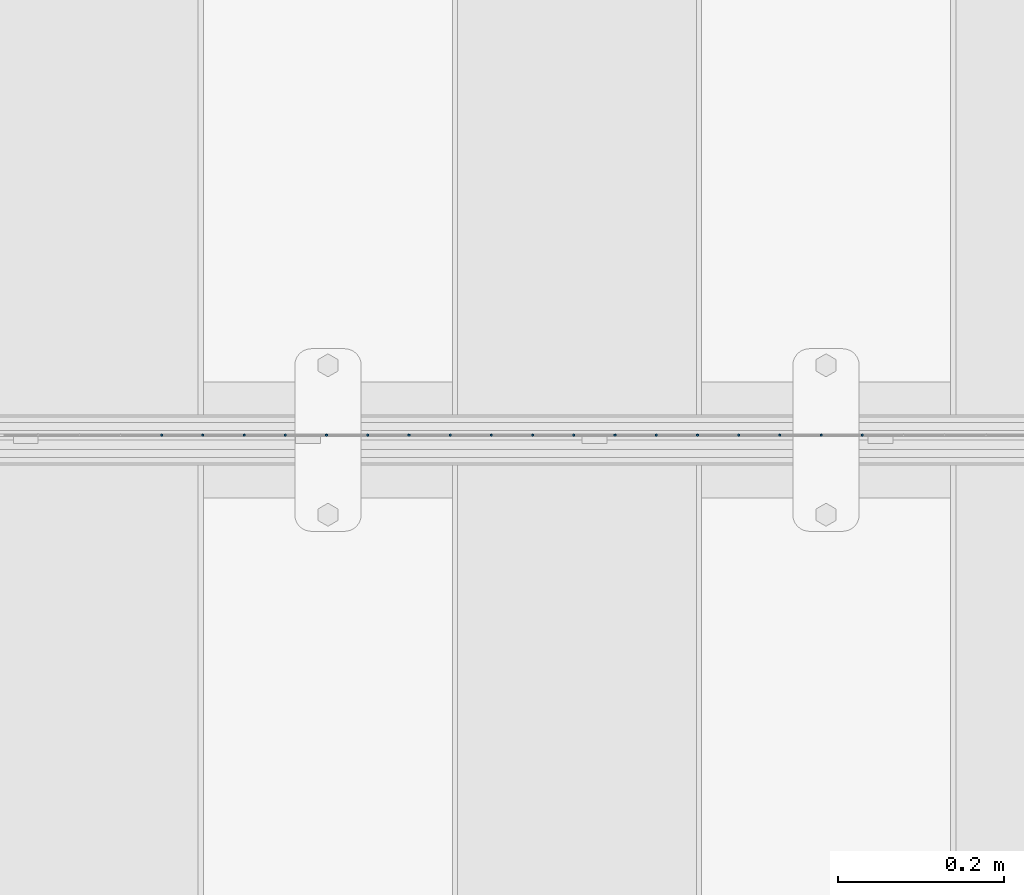
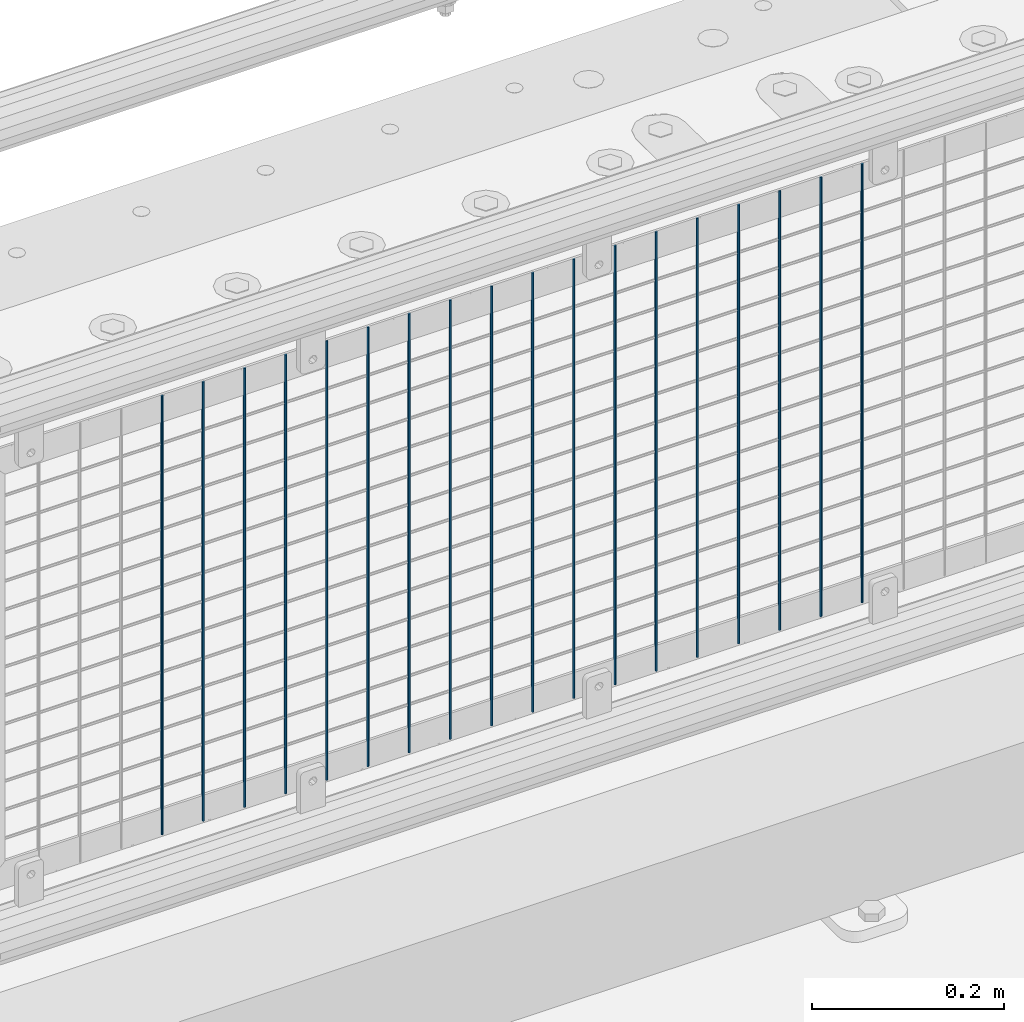
# One storey, part 61 of 208: 18 columns.
"""IFC2X3 building model written with IfcOpenShell, lengths in millimetres."""

from ifc_helpers import new_model, si_unit, frame, origin_with_axes, place, context, subcontext, project, spatial, faceted_brep, material, type_object, element, save


model = new_model("IFC2X3")

# Units and contexts
model_context = context("Model", 3, precision=1e-05, world=origin_with_axes())
body_context = subcontext(model_context, "Body", "Model", "MODEL_VIEW")
ifc_project = project(units=[si_unit("LENGTHUNIT", "METRE", prefix="MILLI"), si_unit("AREAUNIT", "SQUARE_METRE"), si_unit("VOLUMEUNIT", "CUBIC_METRE"), si_unit("MASSUNIT", "GRAM", prefix="KILO"), si_unit("TIMEUNIT", "SECOND"), si_unit("PLANEANGLEUNIT", "RADIAN"), si_unit("SOLIDANGLEUNIT", "STERADIAN"), si_unit("THERMODYNAMICTEMPERATUREUNIT", "DEGREE_CELSIUS"), si_unit("LUMINOUSINTENSITYUNIT", "LUMEN")], contexts=[model_context])

# Site, building, storey
site_placement = place(None, origin_with_axes())
site = spatial("IfcSite", under=ifc_project, at=site_placement, CompositionType="ELEMENT")
building_placement = place(site_placement, origin_with_axes())
building = spatial("IfcBuilding", under=site, at=building_placement, Name="Standard", CompositionType="ELEMENT")
storey_placement = place(building_placement, origin_with_axes())
storey = spatial("IfcBuildingStorey", under=building, at=storey_placement, Name="Undefined", CompositionType="ELEMENT", Elevation=0.0)

# Columns
ifc_material = material(Name="Misc_Undefined")
column_type = type_object("IfcColumnType", Name="D3", PredefinedType="NOTDEFINED")
for number, where, z_axis, x_axis in (
    (1, (-37506.245, 4670.5, 353.02), (-1.0, 0.0, 0.0), (0.0, 0.0, 1.0)),
    (2, (-37555.9, 4670.5, 353.02), (-1.0, 0.0, 0.0), (0.0, 0.0, 1.0)),
    (3, (-37605.555, 4670.5, 353.02), (-1.0, 0.0, 0.0), (0.0, 0.0, 1.0)),
    (4, (-37655.21, 4670.5, 353.02), (-1.0, 0.0, 0.0), (0.0, 0.0, 1.0)),
    (5, (-37704.865, 4670.5, 353.02), (-1.0, 0.0, 0.0), (0.0, 0.0, 1.0)),
    (6, (-37754.52, 4670.5, 353.02), (-1.0, 0.0, 0.0), (0.0, 0.0, 1.0)),
    (7, (-37804.175, 4670.5, 353.02), (-1.0, 0.0, 0.0), (0.0, 0.0, 1.0)),
    (8, (-37853.83, 4670.5, 353.02), (-1.0, 0.0, 0.0), (0.0, 0.0, 1.0)),
    (9, (-37903.485, 4670.5, 353.02), (-1.0, 0.0, 0.0), (0.0, 0.0, 1.0)),
    (10, (-37953.14, 4670.5, 353.02), (-1.0, 0.0, 0.0), (0.0, 0.0, 1.0)),
    (11, (-38002.795, 4670.5, 353.02), (-1.0, 0.0, 0.0), (0.0, 0.0, 1.0)),
    (12, (-38052.45, 4670.5, 353.02), (-1.0, 0.0, 0.0), (0.0, 0.0, 1.0)),
    (13, (-38102.105, 4670.5, 353.02), (-1.0, 0.0, 0.0), (0.0, 0.0, 1.0)),
    (14, (-38151.76, 4670.5, 353.02), (-1.0, 0.0, 0.0), (0.0, 0.0, 1.0)),
    (15, (-38201.415, 4670.5, 353.02), (-1.0, 0.0, 0.0), (0.0, 0.0, 1.0)),
    (16, (-38251.07, 4670.5, 353.02), (-1.0, 0.0, 0.0), (0.0, 0.0, 1.0)),
    (17, (-38300.725, 4670.5, 353.02), (-1.0, 0.0, 0.0), (0.0, 0.0, 1.0)),
    (18, (-38350.38, 4670.5, 353.02), (-1.0, 0.0, 0.0), (0.0, 0.0, 1.0)),
):
    element("IfcColumn", number, at=place(storey_placement, frame(where, z_axis=z_axis, x_axis=x_axis)), inside=storey, type_object=column_type, material=ifc_material, ObjectType="D3", context=body_context, shape_type="Brep", body=[
        faceted_brep([(0.0, -1.49999999999909, 3.63797880709171e-12), (-7.27595761418343e-12, -0.749999999999091, -1.29903810567669), (560.0, -0.75, -1.29903810567703), (560.0, -1.5, 0.0), (-3.63797880709171e-12, 0.750000000000909, -1.29903810567669), (560.0, 0.75, -1.29903810567703), (0.0, 1.50000000000182, 3.63797880709171e-12), (560.0, 1.5, 0.0), (-3.63797880709171e-12, 0.750000000000909, 1.29903810567669), (560.0, 0.75, 1.29903810567703), (-7.27595761418343e-12, -0.749999999999091, 1.29903810567669), (560.0, -0.75, 1.29903810567703)], [[[0, 1, 2, 3]], [[1, 4, 5, 2]], [[4, 6, 7, 5]], [[6, 8, 9, 7]], [[8, 10, 11, 9]], [[10, 0, 3, 11]], [[5, 7, 9, 11, 3, 2]], [[10, 8, 6, 4, 1, 0]]]),
    ])

save(model, "model.ifc")
